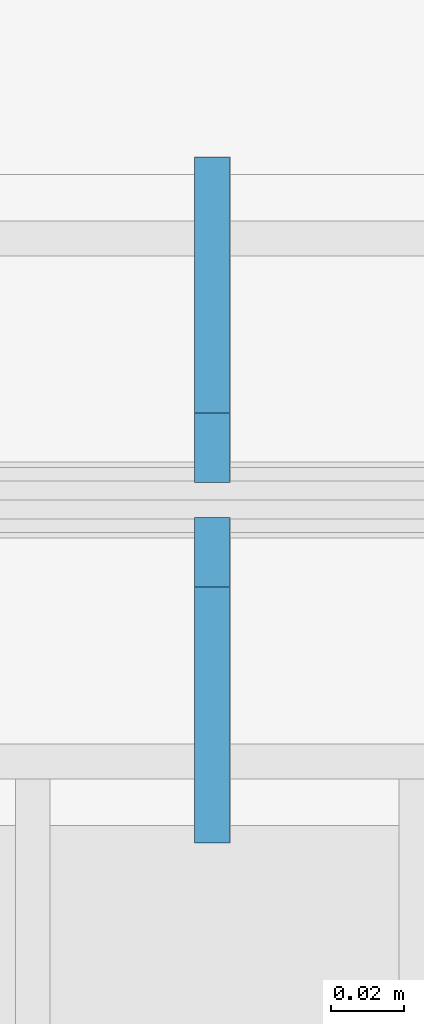
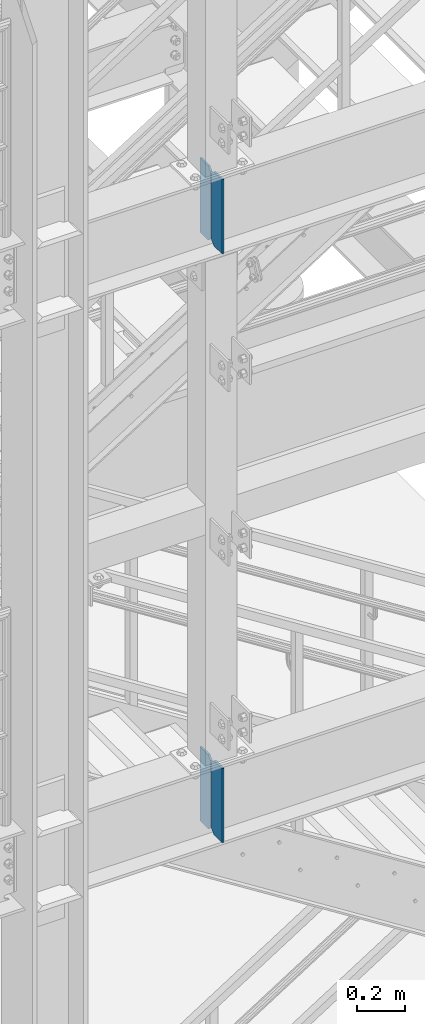
# One storey, part 1434 of 1876: 4 plates, 2 elements without a shape of their own.
"""IFC2X3 building model written with IfcOpenShell, lengths in millimetres."""

from ifc_helpers import new_model, si_unit, frame, origin_with_axes, place, context, subcontext, project, spatial, faceted_brep, material, type_object, element, aggregate, save


model = new_model("IFC2X3")

# Units and contexts
model_context = context("Model", 3, precision=1e-05, world=origin_with_axes())
body_context = subcontext(model_context, "Body", "Model", "MODEL_VIEW")
ifc_project = project(units=[si_unit("LENGTHUNIT", "METRE", prefix="MILLI"), si_unit("AREAUNIT", "SQUARE_METRE"), si_unit("VOLUMEUNIT", "CUBIC_METRE"), si_unit("MASSUNIT", "GRAM", prefix="KILO"), si_unit("TIMEUNIT", "SECOND"), si_unit("PLANEANGLEUNIT", "RADIAN"), si_unit("SOLIDANGLEUNIT", "STERADIAN"), si_unit("THERMODYNAMICTEMPERATUREUNIT", "DEGREE_CELSIUS"), si_unit("LUMINOUSINTENSITYUNIT", "LUMEN")], contexts=[model_context])

# Site, building, storey
site_placement = place(None, origin_with_axes())
site = spatial("IfcSite", under=ifc_project, at=site_placement, CompositionType="ELEMENT")
building_placement = place(site_placement, origin_with_axes())
building = spatial("IfcBuilding", under=site, at=building_placement, Name="Undefined", CompositionType="ELEMENT")
storey_placement = place(building_placement, origin_with_axes())
storey = spatial("IfcBuildingStorey", under=building, at=storey_placement, Name="Undefined", CompositionType="ELEMENT", Elevation=0.0)

# Assembly, plates
assembly_1_placement = place(storey_placement, origin_with_axes())
assembly_1 = element("IfcElementAssembly", 1, at=assembly_1_placement, inside=storey, Name="BEAM", AssemblyPlace="NOTDEFINED", PredefinedType="RIGID_FRAME")
ifc_material = material(Name="STEEL/A36")
plate_type = type_object("IfcPlateType", PredefinedType="NOTDEFINED")
plate_1_placement = place(assembly_1_placement, frame((2539.74997226604, -7205.6625, 7758.1125), z_axis=(0.0, 0.0, 1.0), x_axis=(0.0, 1.0, 0.0)))
plate_1 = element("IfcPlate", 2, at=plate_1_placement, type_object=plate_type, material=ifc_material, Name="PLATE", context=body_context, shape_type="Brep", body=[
    faceted_brep([(0.0, -4.76249999999982, 0.0), (0.0, -4.76250000000073, 381.0), (0.0, 4.76250000000073, 381.0), (0.0, 4.76249999999982, 0.0), (69.8500022888184, -4.76249999999982, 381.0), (69.8500022888184, 4.76249999999982, 381.0), (88.9000015258789, -4.76249999999982, 361.950000762939), (88.9000015258789, 4.76249999999982, 361.950000762939), (88.9000015258789, -4.76249999999982, 19.0499992370605), (88.9000015258789, 4.76249999999982, 19.0499992370605), (69.8500022888184, -4.76249999999982, 0.0), (69.8500022888184, 4.76249999999982, 0.0)], [[[0, 1, 2, 3]], [[1, 4, 5, 2]], [[4, 6, 7, 5]], [[6, 8, 9, 7]], [[8, 10, 11, 9]], [[10, 0, 3, 11]], [[5, 7, 9, 11, 3, 2]], [[10, 8, 6, 4, 1, 0]]]),
])
plate_2_placement = place(assembly_1_placement, frame((2539.74997226604, -7107.2375, 7758.1125), z_axis=(0.0, 0.0, 1.0), x_axis=(0.0, 1.0, 0.0)))
plate_2 = element("IfcPlate", 3, at=plate_2_placement, type_object=plate_type, material=ifc_material, Name="PLATE", context=body_context, shape_type="Brep", body=[
    faceted_brep([(0.0, -4.76249999999982, 19.0499992370605), (0.0, -4.76249999999982, 361.950000762939), (0.0, 4.76249999999982, 361.950000762939), (0.0, 4.76249999999982, 19.0499992370605), (19.0499992370605, -4.76249999999982, 381.0), (19.0499992370605, 4.76249999999982, 381.0), (88.9000015258789, -4.76249999999982, 381.0), (88.9000015258789, 4.76249999999982, 381.0), (88.9000015258789, -4.76249999999982, 0.0), (88.9000015258789, 4.76249999999982, 0.0), (19.0499992370605, -4.76249999999982, 0.0), (19.0499992370605, 4.76249999999982, 0.0)], [[[0, 1, 2, 3]], [[1, 4, 5, 2]], [[4, 6, 7, 5]], [[6, 8, 9, 7]], [[8, 10, 11, 9]], [[10, 0, 3, 11]], [[5, 7, 9, 11, 3, 2]], [[10, 8, 6, 4, 1, 0]]]),
])
aggregate(assembly_1, [plate_1, plate_2])

assembly_2_placement = place(storey_placement, origin_with_axes())
assembly_2 = element("IfcElementAssembly", 4, at=assembly_2_placement, inside=storey, Name="BEAM", AssemblyPlace="NOTDEFINED", PredefinedType="RIGID_FRAME")
plate_3_placement = place(assembly_2_placement, frame((2539.74997226604, -7205.6625, 4735.5125), z_axis=(0.0, 0.0, 1.0), x_axis=(0.0, 1.0, 0.0)))
plate_3 = element("IfcPlate", 5, at=plate_3_placement, type_object=plate_type, material=ifc_material, Name="PLATE", context=body_context, shape_type="Brep", body=[
    faceted_brep([(0.0, -4.76249999999982, 0.0), (0.0, -4.76250000000073, 381.0), (0.0, 4.76250000000073, 381.0), (0.0, 4.76249999999982, 0.0), (69.8500022888184, -4.76249999999982, 381.0), (69.8500022888184, 4.76249999999982, 381.0), (88.9000015258789, -4.76249999999982, 361.950000762939), (88.9000015258789, 4.76249999999982, 361.950000762939), (88.9000015258789, -4.76249999999982, 19.0499992370605), (88.9000015258789, 4.76249999999982, 19.0499992370605), (69.8500022888184, -4.76249999999982, 0.0), (69.8500022888184, 4.76249999999982, 0.0)], [[[0, 1, 2, 3]], [[1, 4, 5, 2]], [[4, 6, 7, 5]], [[6, 8, 9, 7]], [[8, 10, 11, 9]], [[10, 0, 3, 11]], [[5, 7, 9, 11, 3, 2]], [[10, 8, 6, 4, 1, 0]]]),
])
plate_4_placement = place(assembly_2_placement, frame((2539.74997226604, -7107.2375, 4735.5125), z_axis=(0.0, 0.0, 1.0), x_axis=(0.0, 1.0, 0.0)))
plate_4 = element("IfcPlate", 6, at=plate_4_placement, type_object=plate_type, material=ifc_material, Name="PLATE", context=body_context, shape_type="Brep", body=[
    faceted_brep([(0.0, -4.76249999999982, 19.0499992370605), (0.0, -4.76249999999982, 361.950000762939), (0.0, 4.76249999999982, 361.950000762939), (0.0, 4.76249999999982, 19.0499992370605), (19.0499992370605, -4.76249999999982, 381.0), (19.0499992370605, 4.76249999999982, 381.0), (88.9000015258789, -4.76249999999982, 381.0), (88.9000015258789, 4.76249999999982, 381.0), (88.9000015258789, -4.76249999999982, 0.0), (88.9000015258789, 4.76249999999982, 0.0), (19.0499992370605, -4.76249999999982, 0.0), (19.0499992370605, 4.76249999999982, 0.0)], [[[0, 1, 2, 3]], [[1, 4, 5, 2]], [[4, 6, 7, 5]], [[6, 8, 9, 7]], [[8, 10, 11, 9]], [[10, 0, 3, 11]], [[5, 7, 9, 11, 3, 2]], [[10, 8, 6, 4, 1, 0]]]),
])
aggregate(assembly_2, [plate_3, plate_4])

save(model, "model.ifc")
